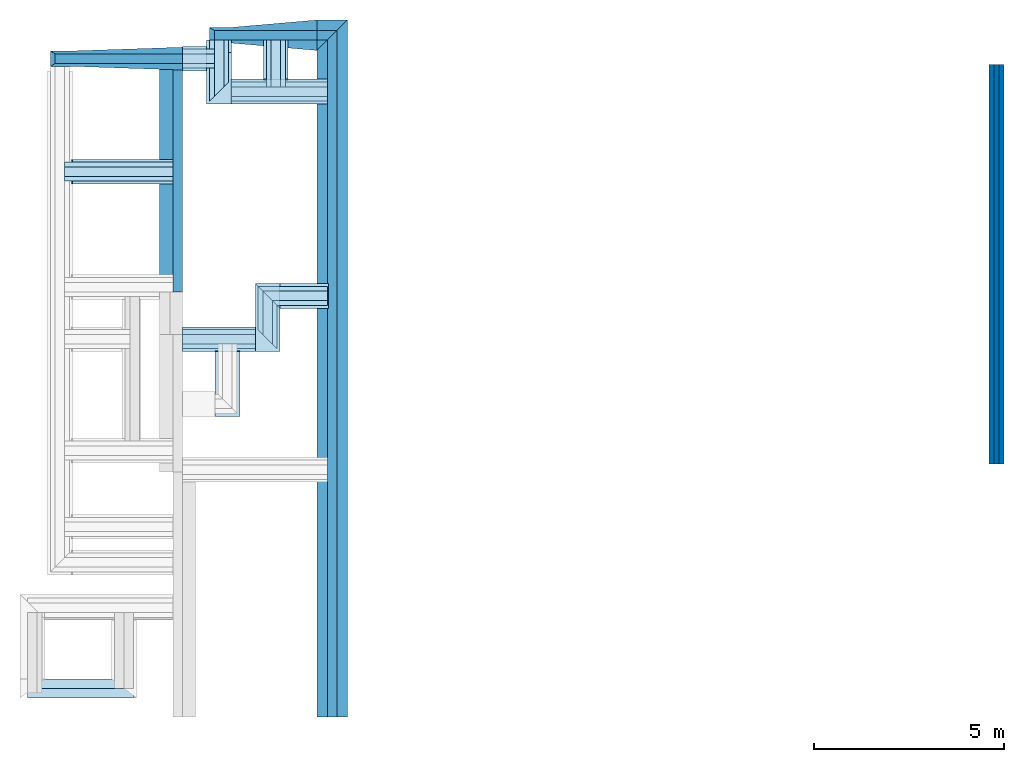
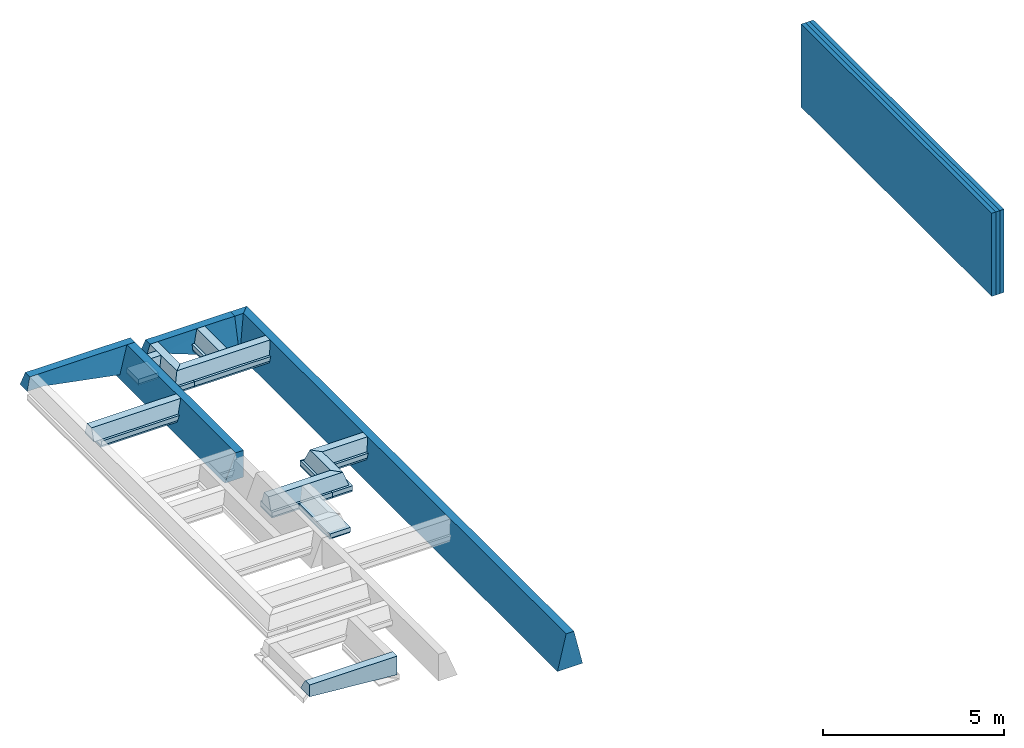
# Not in any storey, part 2 of 2: 32 footings, 3 walls.
"""IFC4 building model written with IfcOpenShell, lengths in millimetres."""

from ifc_helpers import new_model, entity, si_unit, converted_unit, frame, origin_with_axes, origin_2d_with_axis, place, context, subcontext, project, spatial, line, indexed_curve, rectangle, outline, extrude, clip, halfspace, polygons, material, layer, layer_set, layer_usage, material_profile, profile_set, profile_usage, type_object, element, save


model = new_model("IFC4")

# Units and contexts
model_context = context("Model", 3, precision=1e-05, world=origin_with_axes())
plan_context = context("Plan", 2, precision=1e-05, world=origin_2d_with_axis())
body_context = subcontext(model_context, "Body", "Model", "MODEL_VIEW")
ifc_project = project(units=[si_unit("VOLUMEUNIT", "CUBIC_METRE"), si_unit("LENGTHUNIT", "METRE", prefix="MILLI"), si_unit("AREAUNIT", "SQUARE_METRE"), converted_unit("PLANEANGLEUNIT", "degree", entity("IfcReal", 0.0174532925199433), si_unit("PLANEANGLEUNIT", "RADIAN"), dimensions=[0, 0, 0, 0, 0, 0, 0])], contexts=[model_context, plan_context])

# Site, building
site_placement = place(None, origin_with_axes())
site = spatial("IfcSite", under=ifc_project, at=site_placement)
building_1_placement = place(site_placement, origin_with_axes())
building_1 = spatial("IfcBuilding", under=site, at=building_1_placement, Name="1")

# Footings
ifc_material_1 = material()
ifc_material_profile_1 = material_profile(ifc_material_1, outline(indexed_curve([(-124.999992370605, 0.0), (124.999992370605, 0.0), (399.999969482422, -1169.0), (-399.999969482422, -1169.0), (-124.999992370605, 0.0)])))
ifc_profile_set_1 = profile_set([ifc_material_profile_1])
ifc_profile_usage_1 = profile_usage(ifc_profile_set_1, cardinal=5)
footing_type_1 = type_object("IfcFootingType", Name="TYPE 1", PredefinedType="FOOTING_BEAM", material=ifc_profile_set_1)
footing_1_placement = place(building_1_placement, frame((0.0, 0.0, 0.0), z_axis=(1.50995783106425e-07, 0.999999999999986, 7.54978986586403e-08), x_axis=(-0.999999999999986, 1.50995797317281e-07, -7.54978986586403e-08)))
element("IfcFooting", 1, at=footing_1_placement, inside=building_1, type_object=footing_type_1, material=ifc_profile_usage_1, Name="Footing", context=body_context, shape_type="Clipping", body=[
    clip(extrude(outline(indexed_curve([(-124.999992370605, 0.0), (124.999992370605, 0.0), (399.999969482422, -1169.0), (-399.999969482422, -1169.0), (-124.999992370605, 0.0)])), origin_with_axes(), (0.0, 0.0, 1.0), 18315.000395904), halfspace(frame((-399.999976158142, -0.00247440266321064, 18315.0005340576), z_axis=(0.707106530666351, -9.55319521267484e-08, 0.707107067108154), x_axis=(-1.35102630203007e-07, -0.999999999999991, 0.0)), False)),
])
ifc_profile_usage_2 = profile_usage(ifc_profile_set_1, cardinal=5)
footing_2_placement = place(building_1_placement, frame((400.002717971802, 17915.0009155273, 0.00127466205401561), z_axis=(-0.999999999999962, -1.94707169498535e-07, 1.9470718370939e-07), x_axis=(1.94707183709392e-07, -0.999999999999974, 1.19209289550778e-07)))
element("IfcFooting", 2, at=footing_2_placement, inside=building_1, type_object=footing_type_1, material=ifc_profile_usage_2, Name="Footing", context=body_context, shape_type="Clipping", body=[
    clip(extrude(outline(indexed_curve([(-124.999992370605, 0.0), (124.999992370605, 0.0), (399.999969482422, -1169.0), (-399.999969482422, -1169.0), (-124.999992370605, 0.0)])), origin_with_axes(), (0.0, 0.0, 1.0), 799.999655783118), halfspace(frame((-399.999529123306, -0.00228843782679178, -0.000138794788995256), z_axis=(0.707107305526733, 1.48916825537526e-07, -0.707106292247772), x_axis=(2.10600038174677e-07, -0.999999999999978, 0.0)), False)),
])
ifc_material_profile_2 = material_profile(ifc_material_1, outline(indexed_curve([(-125.000193715096, -899.999976158142), (474.999815225601, -899.999976158142), (125.0, 0.0), (-125.0, 0.0), (-125.000193715096, -899.999976158142)])))
ifc_profile_set_2 = profile_set([ifc_material_profile_2])
ifc_profile_usage_3 = profile_usage(ifc_profile_set_2, cardinal=5)
footing_type_2 = type_object("IfcFootingType", Name="TYPE 2", PredefinedType="FOOTING_BEAM", material=ifc_profile_set_2)
footing_3_placement = place(building_1_placement, frame((-4059.99517440796, 11175.0040054321, 735.003769397736), z_axis=(3.89414367418746e-07, 0.999999999999875, 3.13916473260139e-07), x_axis=(-0.999999999999924, 3.89414367418765e-07, 3.8643335753538e-10)))
element("IfcFooting", 3, at=footing_3_placement, inside=building_1, type_object=footing_type_2, material=ifc_profile_usage_3, Name="Footing", context=body_context, shape_type="SweptSolid", body=[
    extrude(outline(indexed_curve([(-125.000193715096, -899.999976158142), (474.999815225601, -899.999976158142), (125.0, 0.0), (-125.0, 0.0), (-125.000193715096, -899.999976158142)])), origin_with_axes(), (0.0, 0.0, 1.0), 5999.99713897715),
])

# Building
building_2_placement = place(site_placement, origin_with_axes())
building_2 = spatial("IfcBuilding", under=site, at=building_2_placement, Name="3")

# Footings
ifc_material_2 = material()
ifc_material_profile_3 = material_profile(ifc_material_2, rectangle(XDim=650.000061035156, YDim=150.0, kind="CURVE"))
ifc_profile_set_3 = profile_set([ifc_material_profile_3])
ifc_profile_usage_4 = profile_usage(ifc_profile_set_3, cardinal=8)
footing_type_3 = type_object("IfcFootingType", Name="60", PredefinedType="FOOTING_BEAM", material=ifc_profile_set_3)
footing_4_placement = place(building_2_placement, frame((-6824.99694824219, 14330.0065994263, 334.999740123749), z_axis=(0.999999999999932, -1.9470714107682e-07, 3.13916473260157e-07), x_axis=(1.94707183709391e-07, 0.99999999999997, -1.49011611938472e-07)))
element("IfcFooting", 4, at=footing_4_placement, inside=building_2, type_object=footing_type_3, material=ifc_profile_usage_4, Name="Footing", context=body_context, shape_type="SweptSolid", body=[
    extrude(rectangle(XDim=650.000061035156, YDim=150.0, kind="CURVE"), frame((0.0, -75.0, 0.0), z_axis=(0.0, 0.0, 1.0), x_axis=(1.0, 0.0, 0.0)), (0.0, 0.0, 1.0), 2639.93880706758),
])
ifc_profile_usage_5 = profile_usage(ifc_profile_set_3, cardinal=8)
footing_5_placement = place(building_1_placement, frame((-2970.00026702881, 16110.0006103516, -399.99982714653), z_axis=(-8.74227765734753e-08, 0.999999999999993, 7.54979012640428e-08), x_axis=(-0.999999999999992, -8.74227765734752e-08, 8.74227836789026e-08)))
element("IfcFooting", 5, at=footing_5_placement, inside=building_1, type_object=footing_type_3, material=ifc_profile_usage_5, Name="Footing", context=body_context, shape_type="SweptSolid", body=[
    extrude(rectangle(XDim=650.000061035156, YDim=150.0, kind="CURVE"), frame((0.0, -75.0, 0.0), z_axis=(0.0, 0.0, 1.0), x_axis=(1.0, 0.0, 0.0)), (0.0, 0.0, 1.0), 1355.00145148452),
])

# Building
building_3_placement = place(site_placement, origin_with_axes())
building_3 = spatial("IfcBuilding", under=site, at=building_3_placement, Name="2")

# Footings
ifc_profile_usage_6 = profile_usage(ifc_profile_set_3, cardinal=8)
footing_6_placement = place(building_3_placement, frame((-124.997548758984, 16435.001373291, -400.0004529953), z_axis=(-0.999999999999962, -1.94707169498535e-07, 1.9470718370939e-07), x_axis=(1.94707183709392e-07, -0.999999999999974, 1.19209289550778e-07)))
element("IfcFooting", 6, at=footing_6_placement, inside=building_3, type_object=footing_type_3, material=ifc_profile_usage_6, Name="Footing", context=body_context, shape_type="SweptSolid", body=[
    extrude(rectangle(XDim=650.000061035156, YDim=150.0, kind="CURVE"), frame((0.0, -75.0, 0.0), z_axis=(0.0, 0.0, 1.0), x_axis=(1.0, 0.0, 0.0)), (0.0, 0.0, 1.0), 2520.00264334167),
])
ifc_profile_usage_7 = profile_usage(ifc_profile_set_3, cardinal=8)
footing_7_placement = place(building_3_placement, frame((-1480.99732398987, 16760.0021362305, -399.999797344208), z_axis=(-8.74227765734753e-08, 0.999999999999993, 7.54979012640428e-08), x_axis=(-0.999999999999992, -8.74227765734752e-08, 8.74227836789026e-08)))
element("IfcFooting", 7, at=footing_7_placement, inside=building_3, type_object=footing_type_3, material=ifc_profile_usage_7, Name="Footing", context=body_context, shape_type="SweptSolid", body=[
    extrude(rectangle(XDim=650.000061035156, YDim=150.0, kind="CURVE"), frame((0.0, -75.0, 0.0), z_axis=(0.0, 0.0, 1.0), x_axis=(1.0, 0.0, 0.0)), (0.0, 0.0, 1.0), 1029.9987716112),
])
ifc_profile_usage_8 = profile_usage(ifc_profile_set_3, cardinal=8)
footing_8_placement = place(building_1_placement, frame((-3295.00031471252, 17300.0011444092, -399.999856948853), z_axis=(-0.999999999999962, -1.94707169498535e-07, 1.9470718370939e-07), x_axis=(1.94707183709392e-07, -0.999999999999974, 1.19209289550778e-07)))
element("IfcFooting", 8, at=footing_8_placement, inside=building_1, type_object=footing_type_3, material=ifc_profile_usage_8, Name="Footing", context=body_context, shape_type="SweptSolid", body=[
    extrude(rectangle(XDim=650.000061035156, YDim=150.0, kind="CURVE"), frame((0.0, -75.0, 0.0), z_axis=(0.0, 0.0, 1.0), x_axis=(1.0, 0.0, 0.0)), (0.0, 0.0, 1.0), 639.99365889121),
])
ifc_profile_usage_9 = profile_usage(ifc_profile_set_3, cardinal=8)
footing_9_placement = place(building_3_placement, frame((-2020.00021934509, 9930.0012588501, -400.000274181366), z_axis=(-0.999999999999962, -1.94707169498535e-07, 1.9470718370939e-07), x_axis=(1.94707183709392e-07, -0.999999999999974, 1.19209289550778e-07)))
element("IfcFooting", 9, at=footing_9_placement, inside=building_3, type_object=footing_type_3, material=ifc_profile_usage_9, Name="Footing", context=body_context, shape_type="SweptSolid", body=[
    extrude(rectangle(XDim=650.000061035156, YDim=150.0, kind="CURVE"), frame((0.0, -75.0, 0.0), z_axis=(0.0, 0.0, 1.0), x_axis=(1.0, 0.0, 0.0)), (0.0, 0.0, 1.0), 1914.99735520784),
])
ifc_profile_usage_10 = profile_usage(ifc_profile_set_3)
footing_10_placement = place(building_3_placement, frame((-124.9985024333, 11065.0014877319, -475.000739097595), z_axis=(-0.999999999999962, -1.94707169498535e-07, 1.9470718370939e-07), x_axis=(1.94707183709392e-07, -0.999999999999974, 1.19209289550778e-07)))
element("IfcFooting", 10, at=footing_10_placement, inside=building_3, type_object=footing_type_3, material=ifc_profile_usage_10, Name="Footing", context=body_context, shape_type="Clipping", body=[
    clip(extrude(rectangle(XDim=650.000061035156, YDim=150.0, kind="CURVE"), origin_with_axes(), (0.0, 0.0, 1.0), 1895.00153986889), halfspace(frame((-325.000196695328, 474.999755620956, 1895.0012922287), z_axis=(0.707106709480286, -1.79825619284202e-07, 0.707106828689575), x_axis=(-2.54311855443099e-07, -0.999999999999968, 0.0)), False)),
])
ifc_profile_usage_11 = profile_usage(ifc_profile_set_3, cardinal=8)
footing_11_placement = place(building_3_placement, frame((-2749.99523162842, 7905.00116348267, -400.000214576721), z_axis=(1.50995802528084e-07, 0.999999999999986, 7.54979012640422e-08), x_axis=(-0.999999999999988, 1.50995802528085e-07, -1.07495621293195e-08)))
element("IfcFooting", 11, at=footing_11_placement, inside=building_3, type_object=footing_type_3, material=ifc_profile_usage_11, Name="Footing", context=body_context, shape_type="SweptSolid", body=[
    extrude(rectangle(XDim=650.000061035156, YDim=150.0, kind="CURVE"), frame((0.0, -75.0, 0.0), z_axis=(0.0, 0.0, 1.0), x_axis=(1.0, 0.0, 0.0)), (0.0, 0.0, 1.0), 1700.00031134661),
])
ifc_profile_usage_12 = profile_usage(ifc_profile_set_3, cardinal=8)
footing_12_placement = place(building_3_placement, frame((-1695.00005245209, 11390.0012969971, -400.000393390656), z_axis=(-1.05030629526936e-07, -0.999999999999992, 7.54979012640427e-08), x_axis=(0.999999999999994, -1.05030629526936e-07, 5.02429578180089e-15)))
element("IfcFooting", 12, at=footing_12_placement, inside=building_3, type_object=footing_type_3, material=ifc_profile_usage_12, Name="Footing", context=body_context, shape_type="Clipping", body=[
    clip(extrude(rectangle(XDim=650.000061035156, YDim=150.0, kind="CURVE"), frame((0.0, -75.0, 0.0), z_axis=(0.0, 0.0, 1.0), x_axis=(1.0, 0.0, 0.0)), (0.0, 0.0, 1.0), 1784.99984890808), halfspace(frame((-324.999690055847, 399.999707937241, 0.000212161793911037), z_axis=(0.707106649875641, 1.12382299022329e-08, -0.70710688829422), x_axis=(1.58932600962095e-08, -1.0, 0.0)), False)),
])
ifc_material_profile_4 = material_profile(ifc_material_1, outline(indexed_curve([(-124.999992370605, 0.0), (124.999992370605, 0.0), (249.999984741211, -399.999969482422), (-249.999984741211, -399.999969482422), (-124.999992370605, 0.0)])))
ifc_profile_set_4 = profile_set([ifc_material_profile_4])
ifc_profile_usage_13 = profile_usage(ifc_profile_set_4)
footing_type_4 = type_object("IfcFootingType", Name="TYPE 3", PredefinedType="FOOTING_BEAM", material=ifc_profile_set_4)
footing_13_placement = place(building_3_placement, frame((-1445.00029087067, 9930.0012588501, -0.000390713324804892), z_axis=(-0.999999999999962, -1.94707169498535e-07, 1.9470718370939e-07), x_axis=(1.94707183709392e-07, -0.999999999999974, 1.19209289550778e-07)))
element("IfcFooting", 13, at=footing_13_placement, inside=building_3, type_object=footing_type_4, material=ifc_profile_usage_13, Name="Footing", context=body_context, shape_type="Clipping", body=[
    clip(extrude(outline(indexed_curve([(-124.999992370605, 0.0), (124.999992370605, 0.0), (249.999984741211, -399.999969482422), (-249.999984741211, -399.999969482422), (-124.999992370605, 0.0)])), origin_with_axes(), (0.0, 0.0, 1.0), 2489.99740370672), halfspace(frame((249.999716877937, -0.00021606192035506, -9.6626308732084e-05), z_axis=(-0.707106709480286, 1.79825605073347e-07, -0.70710676908493), x_axis=(2.54311835345914e-07, 0.999999999999968, 0.0)), False)),
])
ifc_profile_usage_14 = profile_usage(ifc_profile_set_4)
footing_14_placement = place(building_3_placement, frame((-124.9985024333, 11065.0014877319, -0.000647727176982471), z_axis=(-0.999999999999962, -1.94707169498535e-07, 1.9470718370939e-07), x_axis=(1.94707183709392e-07, -0.999999999999974, 1.19209289550778e-07)))
element("IfcFooting", 14, at=footing_14_placement, inside=building_3, type_object=footing_type_4, material=ifc_profile_usage_14, Name="Footing", context=body_context, shape_type="Clipping", body=[
    clip(extrude(outline(indexed_curve([(-124.999992370605, 0.0), (124.999992370605, 0.0), (249.999984741211, -399.999969482422), (-249.999984741211, -399.999969482422), (-124.999992370605, 0.0)])), origin_with_axes(), (0.0, 0.0, 1.0), 1820.00173118009), halfspace(frame((-250.000387430191, -0.000351264390019423, 1820.00160217285), z_axis=(0.707106709480286, -1.79825605073347e-07, 0.70710676908493), x_axis=(-2.54311835345914e-07, -0.999999999999968, 0.0)), False)),
])
ifc_profile_usage_15 = profile_usage(ifc_profile_set_4)
footing_15_placement = place(building_3_placement, frame((-1695.00017166138, 11315.0014877319, -0.000392699462281598), z_axis=(-1.05030629526936e-07, -0.999999999999992, 7.54979012640427e-08), x_axis=(0.999999999999994, -1.05030629526936e-07, 5.02429578180089e-15)))
element("IfcFooting", 15, at=footing_15_placement, inside=building_3, type_object=footing_type_4, material=ifc_profile_usage_15, Name="Footing", context=body_context, shape_type="Clipping", body=[
    clip(clip(extrude(outline(indexed_curve([(-124.999992370605, 0.0), (124.999992370605, 0.0), (249.999984741211, -399.999969482422), (-249.999984741211, -399.999969482422), (-124.999992370605, 0.0)])), origin_with_axes(), (0.0, 0.0, 1.0), 1635.0001961011), halfspace(frame((-250.0, -0.000281727238871099, 0.000204284532401289), z_axis=(0.707106590270996, 1.12382299022329e-08, -0.70710688829422), x_axis=(1.58932614359115e-08, -1.0, 0.0)), False)), halfspace(frame((250.000178813934, -0.000307712696212548, 1635.00034809113), z_axis=(-0.707106590270996, -1.12382299022329e-08, 0.70710688829422), x_axis=(-1.58932614359115e-08, 1.0, 0.0)), False)),
])
ifc_profile_usage_16 = profile_usage(ifc_profile_set_4)
footing_16_placement = place(building_3_placement, frame((-124.997548758984, 16435.001373291, -0.000623388701001204), z_axis=(-0.999999999999962, -1.94707169498535e-07, 1.9470718370939e-07), x_axis=(1.94707183709392e-07, -0.999999999999974, 1.19209289550778e-07)))
element("IfcFooting", 16, at=footing_16_placement, inside=building_3, type_object=footing_type_4, material=ifc_profile_usage_16, Name="Footing", context=body_context, shape_type="Clipping", body=[
    clip(extrude(outline(indexed_curve([(-124.999992370605, 0.0), (124.999992370605, 0.0), (249.999984741211, -399.999969482422), (-249.999984741211, -399.999969482422), (-124.999992370605, 0.0)])), origin_with_axes(), (0.0, 0.0, 1.0), 3095.00266252203), halfspace(frame((249.99937415123, -0.000692232845267426, 3095.0026512146), z_axis=(-0.707107067108154, -3.37146204287819e-08, 0.707106471061707), x_axis=(-4.76796541811753e-08, 0.999999999999999, 0.0)), False)),
])
ifc_profile_usage_17 = profile_usage(ifc_profile_set_4)
footing_17_placement = place(building_3_placement, frame((-1480.99732398987, 16560.001373291, 2.30383250254818e-05), z_axis=(-8.74227765734753e-08, 0.999999999999993, 7.54979012640428e-08), x_axis=(-0.999999999999992, -8.74227765734752e-08, 8.74227836789026e-08)))
element("IfcFooting", 17, at=footing_17_placement, inside=building_3, type_object=footing_type_4, material=ifc_profile_usage_17, Name="Footing", context=body_context, shape_type="SweptSolid", body=[
    extrude(outline(indexed_curve([(-124.999992370605, 0.0), (124.999992370605, 0.0), (249.999984741211, -399.999969482422), (-249.999984741211, -399.999969482422), (-124.999992370605, 0.0)])), origin_with_axes(), (0.0, 0.0, 1.0), 1229.99956177495),
])
ifc_profile_usage_18 = profile_usage(ifc_profile_set_4)
footing_18_placement = place(building_2_placement, frame((-7024.99675750732, 14330.0065994263, 734.999597072601), z_axis=(0.999999999999932, -1.9470714107682e-07, 3.13916473260157e-07), x_axis=(1.94707183709391e-07, 0.99999999999997, -1.49011611938472e-07)))
element("IfcFooting", 18, at=footing_18_placement, inside=building_2, type_object=footing_type_4, material=ifc_profile_usage_18, Name="Footing", context=body_context, shape_type="SweptSolid", body=[
    extrude(outline(indexed_curve([(-124.999992370605, 0.0), (124.999992370605, 0.0), (249.999984741211, -399.999969482422), (-249.999984741211, -399.999969482422), (-124.999992370605, 0.0)])), origin_with_axes(), (0.0, 0.0, 1.0), 2839.93861736562),
])
ifc_profile_usage_19 = profile_usage(ifc_profile_set_4)
footing_19_placement = place(building_1_placement, frame((-2970.00026702881, 16185.001373291, -5.27344390377493e-06), z_axis=(-8.74227765734753e-08, 0.999999999999993, 7.54979012640428e-08), x_axis=(-0.999999999999992, -8.74227765734752e-08, 8.74227836789026e-08)))
element("IfcFooting", 19, at=footing_19_placement, inside=building_1, type_object=footing_type_4, material=ifc_profile_usage_19, Name="Footing", context=body_context, shape_type="Clipping", body=[
    clip(extrude(outline(indexed_curve([(-124.999992370605, 0.0), (124.999992370605, 0.0), (249.999984741211, -399.999969482422), (-249.999984741211, -399.999969482422), (-124.999992370605, 0.0)])), origin_with_axes(), (0.0, 0.0, 1.0), 1604.99955720987), halfspace(frame((250.000029802322, -0.000699782390256587, 0.000281501286281127), z_axis=(-0.707106530666351, 9.55319734430304e-08, -0.70710700750351), x_axis=(1.35102660348793e-07, 0.999999999999991, 0.0)), False)),
])
ifc_profile_usage_20 = profile_usage(ifc_profile_set_4)
footing_20_placement = place(building_1_placement, frame((-3095.00026702881, 17300.0011444092, -4.51078179821707e-05), z_axis=(-0.999999999999962, -1.94707169498535e-07, 1.9470718370939e-07), x_axis=(1.94707183709392e-07, -0.999999999999974, 1.19209289550778e-07)))
element("IfcFooting", 20, at=footing_20_placement, inside=building_1, type_object=footing_type_4, material=ifc_profile_usage_20, Name="Footing", context=body_context, shape_type="SweptSolid", body=[
    extrude(outline(indexed_curve([(-124.999992370605, 0.0), (124.999992370605, 0.0), (249.999984741211, -399.999969482422), (-249.999984741211, -399.999969482422), (-124.999992370605, 0.0)])), origin_with_axes(), (0.0, 0.0, 1.0), 839.993698573335),
])
ifc_material_3 = material()
ifc_material_profile_5 = material_profile(ifc_material_3, rectangle(XDim=650.000061035156, YDim=50.0, kind="CURVE"))
ifc_profile_set_5 = profile_set([ifc_material_profile_5])
ifc_profile_usage_21 = profile_usage(ifc_profile_set_5, cardinal=8)
footing_type_5 = type_object("IfcFootingType", Name="60", PredefinedType="FOOTING_BEAM", material=ifc_profile_set_5)
footing_21_placement = place(building_3_placement, frame((-99.9984070658684, 11065.0014877319, -550.000846385956), z_axis=(-0.999999999999962, -1.94707169498535e-07, 1.9470718370939e-07), x_axis=(1.94707183709392e-07, -0.999999999999974, 1.19209289550778e-07)))
element("IfcFooting", 21, at=footing_21_placement, inside=building_3, type_object=footing_type_5, material=ifc_profile_usage_21, Name="Footing", context=body_context, shape_type="SweptSolid", body=[
    extrude(rectangle(XDim=650.000061035156, YDim=50.0, kind="CURVE"), frame((0.0, -25.0, 0.0), z_axis=(0.0, 0.0, 1.0), x_axis=(1.0, 0.0, 0.0)), (0.0, 0.0, 1.0), 1270.0015092075),
])
ifc_profile_usage_22 = profile_usage(ifc_profile_set_5, cardinal=8)
footing_22_placement = place(building_1_placement, frame((-3295.00031471252, 17300.0011444092, -550.000131130219), z_axis=(-0.999999999999962, -1.94707169498535e-07, 1.9470718370939e-07), x_axis=(1.94707183709392e-07, -0.999999999999974, 1.19209289550778e-07)))
element("IfcFooting", 22, at=footing_22_placement, inside=building_1, type_object=footing_type_5, material=ifc_profile_usage_22, Name="Footing", context=body_context, shape_type="SweptSolid", body=[
    extrude(rectangle(XDim=650.000061035156, YDim=50.0, kind="CURVE"), frame((0.0, -25.0, 0.0), z_axis=(0.0, 0.0, 1.0), x_axis=(1.0, 0.0, 0.0)), (0.0, 0.0, 1.0), 639.99365889121),
])
ifc_profile_usage_23 = profile_usage(ifc_profile_set_5, cardinal=8)
footing_23_placement = place(building_3_placement, frame((-1480.99732398987, 16735.0006103516, -549.999952316284), z_axis=(-8.74227765734753e-08, 0.999999999999993, 7.54979012640428e-08), x_axis=(-0.999999999999992, -8.74227765734752e-08, 8.74227836789026e-08)))
element("IfcFooting", 23, at=footing_23_placement, inside=building_3, type_object=footing_type_5, material=ifc_profile_usage_23, Name="Footing", context=body_context, shape_type="SweptSolid", body=[
    extrude(rectangle(XDim=650.000061035156, YDim=50.0, kind="CURVE"), frame((0.0, -25.0, 0.0), z_axis=(0.0, 0.0, 1.0), x_axis=(1.0, 0.0, 0.0)), (0.0, 0.0, 1.0), 1055.00031530006),
])
ifc_profile_usage_24 = profile_usage(ifc_profile_set_5, cardinal=8)
footing_24_placement = place(building_3_placement, frame((-124.997548758984, 16435.001373291, -550.000667572021), z_axis=(-0.999999999999962, -1.94707169498535e-07, 1.9470718370939e-07), x_axis=(1.94707183709392e-07, -0.999999999999974, 1.19209289550778e-07)))
element("IfcFooting", 24, at=footing_24_placement, inside=building_3, type_object=footing_type_5, material=ifc_profile_usage_24, Name="Footing", context=body_context, shape_type="SweptSolid", body=[
    extrude(rectangle(XDim=650.000061035156, YDim=50.0, kind="CURVE"), frame((0.0, -25.0, 0.0), z_axis=(0.0, 0.0, 1.0), x_axis=(1.0, 0.0, 0.0)), (0.0, 0.0, 1.0), 2545.00272304791),
])
ifc_profile_usage_25 = profile_usage(ifc_profile_set_5, cardinal=8)
footing_25_placement = place(building_3_placement, frame((-1695.00005245209, 11390.0012969971, -550.000667572021), z_axis=(-1.05030629526936e-07, -0.999999999999992, 7.54979012640427e-08), x_axis=(0.999999999999994, -1.05030629526936e-07, 5.02429578180089e-15)))
element("IfcFooting", 25, at=footing_25_placement, inside=building_3, type_object=footing_type_5, material=ifc_profile_usage_25, Name="Footing", context=body_context, shape_type="SweptSolid", body=[
    extrude(rectangle(XDim=650.000061035156, YDim=50.0, kind="CURVE"), frame((0.0, -25.0, 0.0), z_axis=(0.0, 0.0, 1.0), x_axis=(1.0, 0.0, 0.0)), (0.0, 0.0, 1.0), 1784.99984890808),
])
ifc_profile_usage_26 = profile_usage(ifc_profile_set_5, cardinal=8)
footing_26_placement = place(building_2_placement, frame((-6849.99704360962, 14330.0065994263, 184.999465942383), z_axis=(0.999999999999932, -1.9470714107682e-07, 3.13916473260157e-07), x_axis=(1.94707183709391e-07, 0.99999999999997, -1.49011611938472e-07)))
element("IfcFooting", 26, at=footing_26_placement, inside=building_2, type_object=footing_type_5, material=ifc_profile_usage_26, Name="Footing", context=body_context, shape_type="SweptSolid", body=[
    extrude(rectangle(XDim=650.000061035156, YDim=50.0, kind="CURVE"), frame((0.0, -25.0, 0.0), z_axis=(0.0, 0.0, 1.0), x_axis=(1.0, 0.0, 0.0)), (0.0, 0.0, 1.0), 2664.93895312303),
])
ifc_profile_usage_27 = profile_usage(ifc_profile_set_5, cardinal=8)
footing_27_placement = place(building_3_placement, frame((-2020.00021934509, 9930.0012588501, -550.000429153442), z_axis=(-0.999999999999962, -1.94707169498535e-07, 1.9470718370939e-07), x_axis=(1.94707183709392e-07, -0.999999999999974, 1.19209289550778e-07)))
element("IfcFooting", 27, at=footing_27_placement, inside=building_3, type_object=footing_type_5, material=ifc_profile_usage_27, Name="Footing", context=body_context, shape_type="SweptSolid", body=[
    extrude(rectangle(XDim=650.000061035156, YDim=50.0, kind="CURVE"), frame((0.0, -25.0, 0.0), z_axis=(0.0, 0.0, 1.0), x_axis=(1.0, 0.0, 0.0)), (0.0, 0.0, 1.0), 1914.99735520784),
])
ifc_profile_usage_28 = profile_usage(ifc_profile_set_5, cardinal=8)
footing_28_placement = place(building_3_placement, frame((-2749.99523162842, 7930.00078201294, -550.000429153442), z_axis=(1.50995802528084e-07, 0.999999999999986, 7.54979012640422e-08), x_axis=(-0.999999999999988, 1.50995802528085e-07, -1.07495621293195e-08)))
element("IfcFooting", 28, at=footing_28_placement, inside=building_3, type_object=footing_type_5, material=ifc_profile_usage_28, Name="Footing", context=body_context, shape_type="SweptSolid", body=[
    extrude(rectangle(XDim=650.000061035156, YDim=50.0, kind="CURVE"), frame((0.0, -25.0, 0.0), z_axis=(0.0, 0.0, 1.0), x_axis=(1.0, 0.0, 0.0)), (0.0, 0.0, 1.0), 1700.00031134661),
])
ifc_profile_usage_29 = profile_usage(ifc_profile_set_5, cardinal=8)
footing_29_placement = place(building_1_placement, frame((-2970.00026702881, 16110.0006103516, -550.000190734863), z_axis=(-8.74227765734753e-08, 0.999999999999993, 7.54979012640428e-08), x_axis=(-0.999999999999992, -8.74227765734752e-08, 8.74227836789026e-08)))
element("IfcFooting", 29, at=footing_29_placement, inside=building_1, type_object=footing_type_5, material=ifc_profile_usage_29, Name="Footing", context=body_context, shape_type="SweptSolid", body=[
    extrude(rectangle(XDim=650.000061035156, YDim=50.0, kind="CURVE"), frame((0.0, -25.0, 0.0), z_axis=(0.0, 0.0, 1.0), x_axis=(1.0, 0.0, 0.0)), (0.0, 0.0, 1.0), 1680.0003115336),
])
footing_30_placement = place(building_1_placement, frame((-399.997711181641, 17915.0009155273, 0.000953674316008346), z_axis=(0.999999999999998, 4.37113882867378e-08, -4.37113882867378e-08), x_axis=(-4.37113882867379e-08, 0.999999999999999, 0.0)))
element("IfcFooting", 30, at=footing_30_placement, inside=building_1, material=ifc_material_1, PredefinedType="STRIP_FOOTING", context=body_context, shape_type="Tessellation", body=[
    polygons([(-399.999969482422, -1169.0, 0.0), (399.999969482422, -1169.0, 0.0), (-124.999992370605, 0.0, 0.0), (124.999992370605, 0.0, 0.0), (-125.000038146973, 5.16284562763758e-05, -2320.00268554688), (-200.000030517578, -400.000915527344, -2320.00268554688), (199.999923706055, -400.000915527344, -2320.00268554688), (124.999923706055, 5.16284562763758e-05, -2320.00268554688), (-125.000038146973, 5.7092391216429e-05, -2695.00244140625), (-200.000030517578, -400.000915527344, -2820.00268554688), (199.999923706055, -400.000915527344, -2820.00268554688), (124.99991607666, 5.7092391216429e-05, -2695.00244140625)], [[[1, 3, 4, 2]], [[5, 6, 10, 9]], [[2, 4, 8, 7]], [[3, 1, 6, 5]], [[4, 3, 5, 8]], [[1, 2, 7, 6]], [[9, 10, 11, 12]], [[8, 5, 9, 12]], [[6, 7, 11, 10]], [[7, 8, 12, 11]]]),
])
footing_31_placement = place(building_1_placement, frame((-3934.99302864075, 17300.0011444092, 735.005140304565), z_axis=(0.0, 0.0, 1.0), x_axis=(1.0, 0.0, 0.0)))
element("IfcFooting", 31, at=footing_31_placement, inside=building_1, material=ifc_material_1, PredefinedType="STRIP_FOOTING", context=body_context, shape_type="Tessellation", body=[
    polygons([(-3.36140547005925e-05, -300.0, -899.999938964844), (-6.85831619193777e-05, 300.0, -899.999938964844), (5.46392311662203e-06, -124.999992370605, 0.0), (-5.46392311662203e-06, 124.999992370605, 0.0), (-2965.00219726562, -124.999992370605, 0.0), (-2965.00219726562, -200.0, -400.000701904297), (-2965.00219726562, 200.0, -400.000701904297), (-2965.00219726562, 124.999992370605, 0.0), (-3340.00219726562, -124.999992370605, 0.0), (-3465.00219726562, -200.0, -400.000701904297), (-3465.00219726562, 200.0, -400.000701904297), (-3340.00219726562, 124.999992370605, 0.0)], [[[1, 3, 4, 2]], [[8, 5, 9, 12]], [[4, 3, 5, 8]], [[1, 2, 7, 6]], [[2, 4, 8, 7]], [[3, 1, 6, 5]], [[10, 11, 12, 9]], [[6, 7, 11, 10]], [[7, 8, 12, 11]], [[5, 6, 10, 9]]]),
])
footing_32_placement = place(building_2_placement, frame((-8065.00053405762, 625.004231929779, 735.000967979431), z_axis=(0.999999999999947, 1.62920642310374e-07, -2.82129974493713e-07), x_axis=(-1.62920684942943e-07, 0.99999999999998, -1.19209275339924e-07)))
element("IfcFooting", 32, at=footing_32_placement, inside=building_2, material=ifc_material_1, Name="Footing", PredefinedType="STRIP_FOOTING", context=body_context, shape_type="Tessellation", body=[
    polygons([(124.999962747097, 3.52677247406064e-05, 2850.00491142273), (374.999701976776, -629.999756813049, 2850.00538825989), (374.999731779099, -399.999916553497, 65.0061890482903), (-124.999962747097, -3.52650317836378e-05, 2850.00443458557), (-125.000149011612, -629.999935626984, 2850.00443458557), (-125.000208616257, -399.999916553497, 65.0061890482903), (-124.999992549419, 1.83402111275655e-05, 65.0062561035156), (124.999977648258, 1.83402111275655e-05, 65.0062561035156)], [[[1, 2, 3]], [[1, 4, 5]], [[7, 6, 5]], [[3, 2, 5]], [[3, 8, 1]], [[5, 2, 1]], [[5, 4, 7]], [[5, 6, 3]], [[8, 7, 4]], [[4, 1, 8]], [[8, 3, 6, 7]]]),
])

# Walls
ifc_layer = layer(ifc_material_2, 130.000015258789)
ifc_layer_set = layer_set([ifc_layer])
ifc_layer_usage_1 = layer_usage(ifc_layer_set, "AXIS2", "NEGATIVE", 0.0)
wall_type = type_object("IfcWallType", Name="wall", PredefinedType="SOLIDWALL", material=ifc_layer_set)
placement_1 = place(building_3_placement, frame((0.0, 0.0, 200.000002980232), z_axis=(0.0, 0.0, 1.0), x_axis=(1.0, 0.0, 0.0)))
placement_2 = place(placement_1, frame((17259.1857910156, 6652.44960784912, 1029.32004630566), z_axis=(0.0, 0.0, 1.0), x_axis=(1.0, 0.0, 0.0)))
wall_1_placement = place(placement_2, frame((129.999160766602, 0.0, 0.000238418579101562), z_axis=(0.0, 0.0, 1.0), x_axis=(1.94707183709394e-07, 0.999999999999981, 0.0)))
element("IfcWall", 33, at=wall_1_placement, type_object=wall_type, material=ifc_layer_usage_1, Name="Wall", context=body_context, shape_type="SweptSolid", body=[
    extrude(outline(indexed_curve([(0.0, -130.000015258789), (0.0, 0.0), (10499.9989100866, 0.0), (10499.9989100866, -130.000015258789)], segments=[line(1, 2, 3, 4, 1)])), origin_with_axes(), (0.0, 0.0, 1.0), 2800.00019073486),
])
ifc_layer_usage_2 = layer_usage(ifc_layer_set, "AXIS2", "NEGATIVE", 0.0)
wall_2_placement = place(placement_2, frame((0.0, 0.0, 0.000238418579101562), z_axis=(0.0, 0.0, 1.0), x_axis=(1.94707183709394e-07, 0.999999999999981, 0.0)))
element("IfcWall", 34, at=wall_2_placement, type_object=wall_type, material=ifc_layer_usage_2, Name="Wall", context=body_context, shape_type="SweptSolid", body=[
    extrude(outline(indexed_curve([(0.0, -130.000015258789), (0.0, 0.0), (10499.9989100865, 0.0), (10499.9989100865, -130.000015258789)], segments=[line(1, 2, 3, 4, 1)])), origin_with_axes(), (0.0, 0.0, 1.0), 2800.00019073486),
])
ifc_layer_usage_3 = layer_usage(ifc_layer_set, "AXIS2", "NEGATIVE", 0.0)
wall_3_placement = place(placement_2, frame((259.998321533203, 0.0, 0.000238418579101562), z_axis=(0.0, 0.0, 1.0), x_axis=(1.94707183709394e-07, 0.999999999999981, 0.0)))
element("IfcWall", 35, at=wall_3_placement, type_object=wall_type, material=ifc_layer_usage_3, Name="Wall", context=body_context, shape_type="SweptSolid", body=[
    extrude(outline(indexed_curve([(0.0, -130.000015258789), (0.0, 0.0), (10499.9989100871, 0.0), (10499.9989100871, -130.000015258789)], segments=[line(1, 2, 3, 4, 1)])), origin_with_axes(), (0.0, 0.0, 1.0), 2800.00019073486),
])

save(model, "model.ifc")
